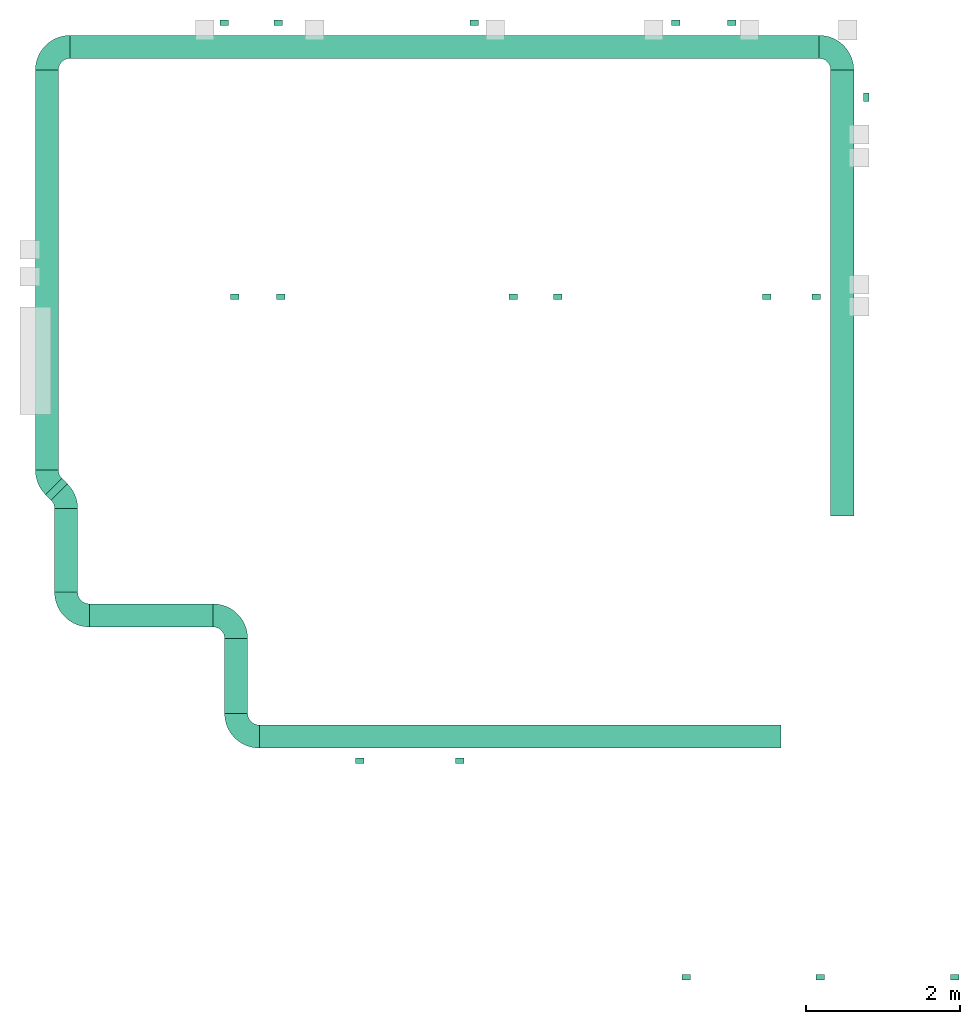
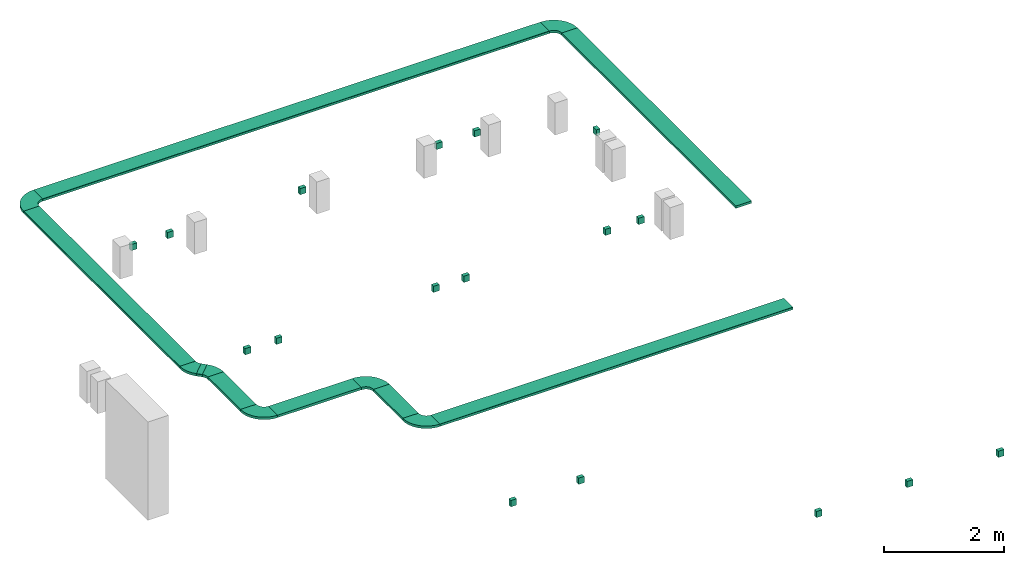
# One storey, part 1 of 2: 17 flow terminals, 15 flow fittings, 8 flow segments.
"""IFC2X3 building model written with IfcOpenShell, lengths in millimetres."""

from ifc_helpers import new_model, entity, si_unit, converted_unit, derived_unit, direction, frame, frame_2d, origin, origin_2d_with_axis, place, context, subcontext, project, spatial, polyline, circle_curve, parameter, trimmed, segment, composite_curve, rectangle, outline, extrude, source, transform, mapped, material, type_object, type_shapes, element, save


model = new_model("IFC2X3")

# Units and contexts
model_context = context("Model", 3, precision=0.01, world=origin(), true_north=direction((6.12303176911189e-17, 1.0)))
body_context = subcontext(model_context, "Body", "Model", "MODEL_VIEW")
ifc_project = project(units=[si_unit("LENGTHUNIT", "METRE", prefix="MILLI"), si_unit("AREAUNIT", "SQUARE_METRE"), si_unit("VOLUMEUNIT", "CUBIC_METRE"), converted_unit("PLANEANGLEUNIT", "DEGREE", entity("IfcRatioMeasure", 0.0174532925199433), si_unit("PLANEANGLEUNIT", "RADIAN"), dimensions=[0, 0, 0, 0, 0, 0, 0]), si_unit("MASSUNIT", "GRAM", prefix="KILO"), derived_unit("MASSDENSITYUNIT", [(si_unit("MASSUNIT", "GRAM", prefix="KILO"), 1), (si_unit("LENGTHUNIT", "METRE"), -3)]), derived_unit("MOMENTOFINERTIAUNIT", [(si_unit("LENGTHUNIT", "METRE"), 4)]), si_unit("TIMEUNIT", "SECOND"), si_unit("FREQUENCYUNIT", "HERTZ"), si_unit("THERMODYNAMICTEMPERATUREUNIT", "DEGREE_CELSIUS"), derived_unit("THERMALTRANSMITTANCEUNIT", [(si_unit("MASSUNIT", "GRAM", prefix="KILO"), 1), (si_unit("THERMODYNAMICTEMPERATUREUNIT", "KELVIN"), -1), (si_unit("TIMEUNIT", "SECOND"), -3)]), derived_unit("VOLUMETRICFLOWRATEUNIT", [(si_unit("LENGTHUNIT", "METRE"), 3), (si_unit("TIMEUNIT", "SECOND"), -1)]), derived_unit("MASSFLOWRATEUNIT", [(si_unit("MASSUNIT", "GRAM", prefix="KILO"), 1), (si_unit("TIMEUNIT", "SECOND"), -1)]), derived_unit("ROTATIONALFREQUENCYUNIT", [(si_unit("TIMEUNIT", "SECOND"), -1)]), si_unit("ELECTRICCURRENTUNIT", "AMPERE"), si_unit("ELECTRICVOLTAGEUNIT", "VOLT"), si_unit("POWERUNIT", "WATT"), si_unit("FORCEUNIT", "NEWTON", prefix="KILO"), si_unit("ILLUMINANCEUNIT", "LUX"), si_unit("LUMINOUSFLUXUNIT", "LUMEN"), si_unit("LUMINOUSINTENSITYUNIT", "CANDELA"), derived_unit("USERDEFINED", [(si_unit("MASSUNIT", "GRAM", prefix="KILO"), -1), (si_unit("LENGTHUNIT", "METRE"), -2), (si_unit("TIMEUNIT", "SECOND"), 3), (si_unit("LUMINOUSFLUXUNIT", "LUMEN"), 1)]), derived_unit("LINEARVELOCITYUNIT", [(si_unit("LENGTHUNIT", "METRE"), 1), (si_unit("TIMEUNIT", "SECOND"), -1)]), si_unit("PRESSUREUNIT", "PASCAL"), derived_unit("USERDEFINED", [(si_unit("LENGTHUNIT", "METRE"), -2), (si_unit("MASSUNIT", "GRAM", prefix="KILO"), 1), (si_unit("TIMEUNIT", "SECOND"), -2)]), derived_unit("LINEARFORCEUNIT", [(si_unit("MASSUNIT", "GRAM", prefix="KILO"), 1), (si_unit("LENGTHUNIT", "METRE"), 1), (si_unit("TIMEUNIT", "SECOND"), -2), (si_unit("LENGTHUNIT", "METRE"), -1)]), derived_unit("PLANARFORCEUNIT", [(si_unit("MASSUNIT", "GRAM", prefix="KILO"), 1), (si_unit("LENGTHUNIT", "METRE"), 1), (si_unit("TIMEUNIT", "SECOND"), -2), (si_unit("LENGTHUNIT", "METRE"), -2)])], contexts=[model_context])

# Site, building, storey
site_placement = place(None, origin())
site = spatial("IfcSite", under=ifc_project, at=site_placement, CompositionType="ELEMENT")
building_placement = place(site_placement, origin())
building = spatial("IfcBuilding", under=site, at=building_placement, CompositionType="ELEMENT")
storey_placement = place(building_placement, frame((0.0, 0.0, 199300.0)))
storey = spatial("IfcBuildingStorey", under=building, at=storey_placement, CompositionType="ELEMENT", Elevation=199300.0)

# Flow segments
cable_carrier_segment_type = type_object("IfcCableCarrierSegmentType", PredefinedType="CABLETRAYSEGMENT")
flow_segment_1_placement = place(storey_placement, frame((31710.0009155271, 13799.9992263561, 3450.0)))
element("IfcFlowSegment", 1, at=flow_segment_1_placement, inside=storey, type_object=cable_carrier_segment_type, context=body_context, shape_type="SweptSolid", body=[
    extrude(rectangle(XDim=5799.00000000001, YDim=300.000000000001, at=origin_2d_with_axis()), frame((150.0, 2899.5, 0.0), z_axis=(0.0, 0.0, 1.0), x_axis=(0.0, -1.0, 0.0)), (0.0, 0.0, 1.0), 50.0000000000233),
])
flow_segment_2_placement = place(storey_placement, frame((24281.1085349551, 10784.9986457573, 3450.0)))
element("IfcFlowSegment", 2, at=flow_segment_2_placement, inside=storey, type_object=cable_carrier_segment_type, context=body_context, shape_type="SweptSolid", body=[
    extrude(rectangle(XDim=6782.9176337415, YDim=300.000000000001, at=frame_2d((2.04636307898909e-12, 1.08002495835535e-12), x_axis=(1.0, 0.0))), frame((3391.45881687075, 150.0, 0.0), z_axis=(0.0, 0.0, 1.0), x_axis=(-1.0, 0.0, 0.0)), (0.0, 0.0, 1.0), 50.0000000000233),
])
flow_segment_3_placement = place(storey_placement, frame((23830.1085349551, 11235.9986457573, 3450.0)))
element("IfcFlowSegment", 3, at=flow_segment_3_placement, inside=storey, type_object=cable_carrier_segment_type, context=body_context, shape_type="SweptSolid", body=[
    extrude(rectangle(XDim=972.188624962087, YDim=300.000000000001, at=origin_2d_with_axis()), frame((150.0, 486.094312481047, 0.0), z_axis=(0.0, 0.0, 1.0), x_axis=(0.0, 1.0, 0.0)), (0.0, 0.0, 1.0), 50.0000000000233),
])
flow_segment_4_placement = place(storey_placement, frame((22071.1085349551, 12359.1872707193, 3450.0)))
element("IfcFlowSegment", 4, at=flow_segment_4_placement, inside=storey, type_object=cable_carrier_segment_type, context=body_context, shape_type="SweptSolid", body=[
    extrude(rectangle(XDim=1608.0, YDim=300.000000000001, at=frame_2d((2.1600499167107e-12, 0.0), x_axis=(1.0, 0.0))), frame((804.0, 150.0, 0.0), z_axis=(0.0, 0.0, 1.0), x_axis=(-1.0, 0.0, 0.0)), (0.0, 0.0, 1.0), 50.0000000000233),
])
flow_segment_5_placement = place(storey_placement, frame((21620.1085349551, 12810.1872707193, 3450.0)))
element("IfcFlowSegment", 5, at=flow_segment_5_placement, inside=storey, type_object=cable_carrier_segment_type, context=body_context, shape_type="SweptSolid", body=[
    extrude(rectangle(XDim=1087.75113021257, YDim=300.000000000001, at=frame_2d((1.08002495835535e-12, -2.17426077142591e-12), x_axis=(1.0, 0.0))), frame((150.0, 543.875565106287, 0.0), z_axis=(0.0, 0.0, 1.0), x_axis=(0.0, 1.0, 0.0)), (0.0, 0.0, 1.0), 50.0000000000233),
])
flow_segment_6_placement = place(storey_placement, frame((21370.1085349482, 14398.4665383627, 3450.0)))
element("IfcFlowSegment", 6, at=flow_segment_6_placement, inside=storey, type_object=cable_carrier_segment_type, context=body_context, shape_type="SweptSolid", body=[
    extrude(rectangle(XDim=5200.53268799345, YDim=300.000000000001, at=origin_2d_with_axis()), frame((150.0, 2600.26634399672, 0.0), z_axis=(0.0, 0.0, 1.0), x_axis=(0.0, -1.0, 0.0)), (0.0, 0.0, 1.0), 50.0000000000233),
])
flow_segment_7_placement = place(storey_placement, frame((21821.1085349482, 19749.9992263561, 3450.0)))
element("IfcFlowSegment", 7, at=flow_segment_7_placement, inside=storey, type_object=cable_carrier_segment_type, context=body_context, shape_type="SweptSolid", body=[
    extrude(rectangle(XDim=9737.89238057895, YDim=300.000000000001, at=origin_2d_with_axis()), frame((4868.94619028947, 150.0, 0.0), z_axis=(0.0, 0.0, 1.0), x_axis=(-1.0, 0.0, 0.0)), (0.0, 0.0, 1.0), 50.0000000000233),
])
flow_segment_8_placement = place(storey_placement, frame((21502.6175901954, 14005.7115248911, 3450.0)))
element("IfcFlowSegment", 8, at=flow_segment_8_placement, inside=storey, type_object=cable_carrier_segment_type, context=body_context, shape_type="SweptSolid", body=[
    extrude(rectangle(XDim=103.025253179211, YDim=299.999999999998, at=frame_2d((-1.53121959556302e-12, -1.52056145452661e-12), x_axis=(1.0, 0.0))), frame((142.49094475622, 142.49094475622, 0.0), z_axis=(0.0, 0.0, 1.0), x_axis=(-0.707106781186558, 0.707106781186537, 0.0)), (0.0, 0.0, 1.0), 50.0000000000233),
])

# Flow fittings
ifc_material = material()
cable_carrier_fitting_type_1 = type_object("IfcCableCarrierFittingType", PredefinedType="NOTDEFINED", material=ifc_material)
shared_shape_1 = source(origin(), body_context, "Body", "SweptSolid", [
    extrude(outline(composite_curve([segment(polyline([(-150.749999999996, -300.250000000003), (-149.749999999994, -300.250000000003)]), True, "CONTINUOUS"), segment(trimmed(circle_curve(frame_2d((-149.750000000002, 149.749999999997), x_axis=(0.0, -1.0)), 450.0), [parameter(0.0)], [parameter(90.0000000000001)], True, "PARAMETER"), True, "CONTINUOUS"), segment(polyline([(300.249999999997, 149.750000000005), (300.249999999997, 150.750000000004)]), True, "CONTINUOUS"), segment(polyline([(300.249999999997, 150.750000000003), (0.249999999997449, 150.750000000002)]), True, "CONTINUOUS"), segment(polyline([(0.249999999997449, 150.750000000002), (0.249999999997438, 149.75)]), True, "CONTINUOUS"), segment(trimmed(circle_curve(frame_2d((-149.750000000002, 149.749999999997), x_axis=(0.0, -1.0)), 150.0), [parameter(0.0)], [parameter(90.0000000000001)], True, "PARAMETER"), False, "CONTINUOUS"), segment(polyline([(-149.749999999999, -0.250000000002818), (-150.750000000001, -0.250000000002835)]), True, "CONTINUOUS"), segment(polyline([(-150.750000000001, -0.250000000002835), (-150.749999999996, -300.250000000003)]), True, "CONTINUOUS")], self_intersect=False)), frame((-150.249999999991, 150.249999999992, -25.0)), (0.0, 0.0, 1.0), 49.9999999999974),
])
type_shapes(cable_carrier_fitting_type_1, [shared_shape_1])
for number, where, z_axis, x_axis in (
    (9, (23980.1085349551, 12509.1872707193, 3475.0), (0.0, 0.0, 1.0), (0.0, 1.0, 0.0)),
    (10, (21770.1085349551, 12509.1872707193, 3475.0), (0.0, 0.0, 1.0), (0.0, -1.0, 0.0)),
    (11, (21520.1085349482, 19899.9992263561, 3475.0), (0.0, 0.0, 1.0), (-1.0, 0.0, 0.0)),
    (12, (31860.0009155271, 19899.9992263561, 3475.0), (0.0, 0.0, 1.0), (0.0, 1.0, 0.0)),
    (13, (23980.1085349551, 10934.9986457573, 3475.0), (0.0, 0.0, 1.0), (0.0, -1.0, 0.0)),
):
    element("IfcFlowFitting", number, at=place(storey_placement, frame(where, z_axis=z_axis, x_axis=x_axis)), inside=storey, type_object=cable_carrier_fitting_type_1, material=ifc_material, context=body_context, shape_type="MappedRepresentation", body=[
        mapped(shared_shape_1, transform((0.0, 0.0, 0.0), scale=1.0)),
    ])
cable_carrier_fitting_type_2 = type_object("IfcCableCarrierFittingType", PredefinedType="NOTDEFINED", material=ifc_material)
shared_shape_2 = source(origin(), body_context, "Body", "SweptSolid", [
    extrude(outline(composite_curve([segment(polyline([(-106.992793873276, -194.110759517316), (-105.992793873275, -194.110759517316)]), True, "CONTINUOUS"), segment(trimmed(circle_curve(frame_2d((-105.992793873283, 255.889240482683), x_axis=(0.0, -1.0)), 450.0), [parameter(0.0)], [parameter(45.0)], True, "PARAMETER"), True, "CONTINUOUS"), segment(polyline([(212.205257660669, -62.3088110512572), (212.912364441855, -61.6017042700708)]), True, "CONTINUOUS"), segment(polyline([(212.912364441855, -61.6017042700708), (0.780330085887347, 150.53033008589)]), True, "CONTINUOUS"), segment(polyline([(0.780330085887396, 150.53033008589), (0.0732233047007628, 149.823223304703)]), True, "CONTINUOUS"), segment(trimmed(circle_curve(frame_2d((-105.992793873283, 255.889240482683), x_axis=(0.0, -1.0)), 150.0), [parameter(0.0)], [parameter(45.0)], True, "PARAMETER"), False, "CONTINUOUS"), segment(polyline([(-105.99279387328, 105.889240482684), (-106.992793873281, 105.889240482684)]), True, "CONTINUOUS"), segment(polyline([(-106.992793873281, 105.889240482684), (-106.992793873276, -194.110759517316)]), True, "CONTINUOUS")], self_intersect=False)), frame((-18.27127483864, 44.1107595173065, -25.0)), (0.0, 0.0, 1.0), 49.9999999999982),
])
type_shapes(cable_carrier_fitting_type_2, [shared_shape_2])
for number, where, z_axis, x_axis in (
    (14, (21770.1085349551, 14023.2024696438, 3475.0), (0.0, 0.0, 1.0), (0.0, 1.0, 0.0)),
    (15, (21520.1085349482, 14273.2024696508, 3475.0), (0.0, 0.0, 1.0), (0.0, -1.0, 0.0)),
):
    element("IfcFlowFitting", number, at=place(storey_placement, frame(where, z_axis=z_axis, x_axis=x_axis)), inside=storey, type_object=cable_carrier_fitting_type_2, material=ifc_material, context=body_context, shape_type="MappedRepresentation", body=[
        mapped(shared_shape_2, transform((0.0, 0.0, 0.0), scale=1.0)),
    ])
cable_carrier_fitting_type_3 = type_object("IfcCableCarrierFittingType", PredefinedType="NOTDEFINED", material=ifc_material)
shared_shape_3 = source(origin(), body_context, "Body", "SweptSolid", [
    extrude(outline(polyline([(-150.0, -2.0), (-149.0, -2.0), (-149.0, 2.0), (149.0, 2.0), (149.0, -3.0), (150.0, -3.0), (150.0, 3.0), (-150.0, 3.0), (-150.0, -2.0)])), frame((0.0, 150.0, 3.0), z_axis=(1.0, 0.0, 0.0), x_axis=(0.0, 1.0, 0.0)), (0.0, 0.0, 1.0), 5200.5),
])
type_shapes(cable_carrier_fitting_type_3, [shared_shape_3])
flow_fitting_1_placement = place(storey_placement, frame((21670.1085349482, 14398.4992263561, 3494.0), z_axis=(0.0, 0.0, 1.0), x_axis=(0.0, 1.0, 0.0)))
element("IfcFlowFitting", 16, at=flow_fitting_1_placement, inside=storey, type_object=cable_carrier_fitting_type_3, material=ifc_material, context=body_context, shape_type="MappedRepresentation", body=[
    mapped(shared_shape_3, transform((0.0, 0.0, 0.0), scale=1.0)),
])
cable_carrier_fitting_type_4 = type_object("IfcCableCarrierFittingType", PredefinedType="NOTDEFINED", material=ifc_material)
shared_shape_4 = source(origin(), body_context, "Body", "SweptSolid", [
    extrude(outline(polyline([(-150.0, -2.0), (-149.0, -2.0), (-149.0, 2.0), (149.0, 2.0), (149.0, -3.0), (150.0, -3.0), (150.0, 3.0), (-150.0, 3.0), (-150.0, -2.0)])), frame((0.0, 150.0, 3.0), z_axis=(1.0, 0.0, 0.0), x_axis=(0.0, 1.0, 0.0)), (0.0, 0.0, 1.0), 9737.9),
])
type_shapes(cable_carrier_fitting_type_4, [shared_shape_4])
flow_fitting_2_placement = place(storey_placement, frame((31559.0085349482, 20049.9992263561, 3494.0), z_axis=(0.0, 0.0, 1.0), x_axis=(-1.0, 0.0, 0.0)))
element("IfcFlowFitting", 17, at=flow_fitting_2_placement, inside=storey, type_object=cable_carrier_fitting_type_4, material=ifc_material, context=body_context, shape_type="MappedRepresentation", body=[
    mapped(shared_shape_4, transform((0.0, 0.0, 0.0), scale=1.0)),
])
cable_carrier_fitting_type_5 = type_object("IfcCableCarrierFittingType", PredefinedType="NOTDEFINED", material=ifc_material)
shared_shape_5 = source(origin(), body_context, "Body", "SweptSolid", [
    extrude(outline(polyline([(-150.0, -2.0), (-149.0, -2.0), (-149.0, 2.0), (149.0, 2.0), (149.0, -3.0), (150.0, -3.0), (150.0, 3.0), (-150.0, 3.0), (-150.0, -2.0)])), frame((0.0, 150.0, 3.0), z_axis=(1.0, 0.0, 0.0), x_axis=(0.0, 1.0, 0.0)), (0.0, 0.0, 1.0), 103.0),
])
type_shapes(cable_carrier_fitting_type_5, [shared_shape_5])
flow_fitting_3_placement = place(storey_placement, frame((21787.5816230136, 14217.8614159413, 3494.0), z_axis=(0.0, 0.0, 1.0), x_axis=(-0.707106781186548, 0.707106781186548, 0.0)))
element("IfcFlowFitting", 18, at=flow_fitting_3_placement, inside=storey, type_object=cable_carrier_fitting_type_5, material=ifc_material, context=body_context, shape_type="MappedRepresentation", body=[
    mapped(shared_shape_5, transform((0.0, 0.0, 0.0), scale=1.0)),
])
cable_carrier_fitting_type_6 = type_object("IfcCableCarrierFittingType", PredefinedType="NOTDEFINED", material=ifc_material)
shared_shape_6 = source(origin(), body_context, "Body", "SweptSolid", [
    extrude(outline(polyline([(-150.0, -2.0), (-149.0, -2.0), (-149.0, 2.0), (149.0, 2.0), (149.0, -3.0), (150.0, -3.0), (150.0, 3.0), (-150.0, 3.0), (-150.0, -2.0)])), frame((0.0, 150.0, 3.0), z_axis=(1.0, 0.0, 0.0), x_axis=(0.0, 1.0, 0.0)), (0.0, 0.0, 1.0), 1087.8),
])
type_shapes(cable_carrier_fitting_type_6, [shared_shape_6])
flow_fitting_4_placement = place(storey_placement, frame((21920.1085349551, 12810.1384009319, 3494.0), z_axis=(0.0, 0.0, 1.0), x_axis=(0.0, 1.0, 0.0)))
element("IfcFlowFitting", 19, at=flow_fitting_4_placement, inside=storey, type_object=cable_carrier_fitting_type_6, material=ifc_material, context=body_context, shape_type="MappedRepresentation", body=[
    mapped(shared_shape_6, transform((0.0, 0.0, 0.0), scale=1.0)),
])
cable_carrier_fitting_type_7 = type_object("IfcCableCarrierFittingType", PredefinedType="NOTDEFINED", material=ifc_material)
shared_shape_7 = source(origin(), body_context, "Body", "SweptSolid", [
    extrude(outline(polyline([(-150.0, -2.0), (-149.0, -2.0), (-149.0, 2.0), (149.0, 2.0), (149.0, -3.0), (150.0, -3.0), (150.0, 3.0), (-150.0, 3.0), (-150.0, -2.0)])), frame((0.0, 150.0, 3.0), z_axis=(1.0, 0.0, 0.0), x_axis=(0.0, 1.0, 0.0)), (0.0, 0.0, 1.0), 5798.96406871193),
])
type_shapes(cable_carrier_fitting_type_7, [shared_shape_7])
flow_fitting_5_placement = place(storey_placement, frame((32010.0009155272, 13799.9992263561, 3494.0), z_axis=(0.0, 0.0, 1.0), x_axis=(0.0, 1.0, 0.0)))
element("IfcFlowFitting", 20, at=flow_fitting_5_placement, inside=storey, type_object=cable_carrier_fitting_type_7, material=ifc_material, context=body_context, shape_type="MappedRepresentation", body=[
    mapped(shared_shape_7, transform((0.0, 0.0, 0.0), scale=1.0)),
])
cable_carrier_fitting_type_8 = type_object("IfcCableCarrierFittingType", PredefinedType="NOTDEFINED", material=ifc_material)
shared_shape_8 = source(origin(), body_context, "Body", "SweptSolid", [
    extrude(outline(polyline([(-150.0, -2.0), (-149.0, -2.0), (-149.0, 2.0), (149.0, 2.0), (149.0, -3.0), (150.0, -3.0), (150.0, 3.0), (-150.0, 3.0), (-150.0, -2.0)])), frame((0.0, 150.0, 3.0), z_axis=(1.0, 0.0, 0.0), x_axis=(0.0, 1.0, 0.0)), (0.0, 0.0, 1.0), 1608.0),
])
type_shapes(cable_carrier_fitting_type_8, [shared_shape_8])
flow_fitting_6_placement = place(storey_placement, frame((22071.1085349551, 12359.1872707194, 3494.0)))
element("IfcFlowFitting", 21, at=flow_fitting_6_placement, inside=storey, type_object=cable_carrier_fitting_type_8, material=ifc_material, context=body_context, shape_type="MappedRepresentation", body=[
    mapped(shared_shape_8, transform((0.0, 0.0, 0.0), scale=1.0)),
])
cable_carrier_fitting_type_9 = type_object("IfcCableCarrierFittingType", PredefinedType="NOTDEFINED", material=ifc_material)
shared_shape_9 = source(origin(), body_context, "Body", "SweptSolid", [
    extrude(outline(polyline([(-150.0, -2.0), (-149.0, -2.0), (-149.0, 2.0), (149.0, 2.0), (149.0, -3.0), (150.0, -3.0), (150.0, 3.0), (-150.0, 3.0), (-150.0, -2.0)])), frame((0.0, 150.0, 3.0), z_axis=(1.0, 0.0, 0.0), x_axis=(0.0, 1.0, 0.0)), (0.0, 0.0, 1.0), 972.2),
])
type_shapes(cable_carrier_fitting_type_9, [shared_shape_9])
flow_fitting_7_placement = place(storey_placement, frame((24130.1085349551, 11235.9986457573, 3494.0), z_axis=(0.0, 0.0, 1.0), x_axis=(0.0, 1.0, 0.0)))
element("IfcFlowFitting", 22, at=flow_fitting_7_placement, inside=storey, type_object=cable_carrier_fitting_type_9, material=ifc_material, context=body_context, shape_type="MappedRepresentation", body=[
    mapped(shared_shape_9, transform((0.0, 0.0, 0.0), scale=1.0)),
])
cable_carrier_fitting_type_10 = type_object("IfcCableCarrierFittingType", PredefinedType="NOTDEFINED", material=ifc_material)
shared_shape_10 = source(origin(), body_context, "Body", "SweptSolid", [
    extrude(outline(polyline([(-150.0, -2.0), (-149.0, -2.0), (-149.0, 2.0), (149.0, 2.0), (149.0, -3.0), (150.0, -3.0), (150.0, 3.0), (-150.0, 3.0), (-150.0, -2.0)])), frame((0.0, 150.0, 3.0), z_axis=(1.0, 0.0, 0.0), x_axis=(0.0, 1.0, 0.0)), (0.0, 0.0, 1.0), 6782.1),
])
type_shapes(cable_carrier_fitting_type_10, [shared_shape_10])
flow_fitting_8_placement = place(storey_placement, frame((24281.1085349551, 10784.9986457573, 3494.0)))
element("IfcFlowFitting", 23, at=flow_fitting_8_placement, inside=storey, type_object=cable_carrier_fitting_type_10, material=ifc_material, context=body_context, shape_type="MappedRepresentation", body=[
    mapped(shared_shape_10, transform((0.0, 0.0, 0.0), scale=1.0)),
])

# Flow terminals
electric_appliance_type = type_object("IfcElectricApplianceType", Name="ADSK_:RT 262 A", PredefinedType="NOTDEFINED", material=ifc_material)
shared_shape_11 = source(origin(), body_context, "Body", "SweptSolid", [
    extrude(rectangle(XDim=71.0, YDim=110.000000000044, at=origin_2d_with_axis()), frame((0.0, 0.0, 0.0), z_axis=(0.0, 0.0, 1.0), x_axis=(-1.0, 0.0, 0.0)), (0.0, 0.0, 1.0), 127.0),
])
type_shapes(electric_appliance_type, [shared_shape_11])
for number, where, z_axis, x_axis, name in (
    (24, (23825.1085349482, 20214.499226356, 1500.0), (0.0, 0.0, 1.0), (0.0, -1.0, 0.0), "ADSK_:RT 262 A"),
    (25, (24525.1085349482, 20214.499226356, 1500.0), (0.0, 0.0, 1.0), (0.0, -1.0, 0.0), "ADSK_:RT 262 A"),
    (26, (27075.1085349482, 20214.499226356, 1500.0), (0.0, 0.0, 1.0), (0.0, -1.0, 0.0), "ADSK_:RT 262 A"),
    (27, (29695.1085349482, 20214.499226356, 1500.0), (0.0, 0.0, 1.0), (0.0, -1.0, 0.0), "ADSK_:RT 262 A"),
    (28, (30425.1085349482, 20214.499226356, 1500.0), (0.0, 0.0, 1.0), (0.0, -1.0, 0.0), "ADSK_:RT 262 A"),
    (29, (32174.5009155272, 19244.9992263562, 1500.0), (0.0, 0.0, 1.0), (-1.0, 0.0, 0.0), "ADSK_:RT 262 A"),
    (30, (31520.0009155271, 16649.999226356, 1500.0), (0.0, 0.0, 1.0), (0.0, 1.0, 0.0), "ADSK_:RT 262 A"),
    (31, (30880.0009155271, 16649.999226356, 1500.0), (0.0, 0.0, 1.0), (0.0, 1.0, 0.0), "ADSK_:RT 262 A"),
    (32, (28160.0009155271, 16649.999226356, 1500.0), (0.0, 0.0, 1.0), (0.0, 1.0, 0.0), "ADSK_:RT 262 A"),
    (33, (27580.0009155271, 16649.999226356, 1500.0), (0.0, 0.0, 1.0), (0.0, 1.0, 0.0), "ADSK_:RT 262 A"),
    (34, (24560.0009155271, 16649.999226356, 1500.0), (0.0, 0.0, 1.0), (0.0, 1.0, 0.0), "ADSK_:RT 262 A"),
    (35, (23960.0009155271, 16649.999226356, 1500.0), (0.0, 0.0, 1.0), (0.0, 1.0, 0.0), "ADSK_:RT 262 A"),
    (36, (25585.1085349551, 10620.4986457573, 1500.0), (0.0, 0.0, 1.0), (0.0, 1.0, 0.0), "ADSK_:RT 262 A"),
    (37, (26885.1085349551, 10620.4986457573, 1500.0), (0.0, 0.0, 1.0), (0.0, 1.0, 0.0), "ADSK_:RT 262 A"),
    (38, (29830.0002685552, 7804.4987060312, 1500.0), (0.0, 0.0, 1.0), (0.0, -1.0, 0.0), "ADSK_:RT 262 A"),
    (39, (31575.0002685552, 7804.4987060312, 1500.0), (0.0, 0.0, 1.0), (0.0, -1.0, 0.0), "ADSK_:RT 262 A"),
    (40, (33325.0002685552, 7804.49870603119, 1500.0), (0.0, 0.0, 1.0), (0.0, -1.0, 0.0), "ADSK_:RT 262 A"),
):
    element("IfcFlowTerminal", number, at=place(storey_placement, frame(where, z_axis=z_axis, x_axis=x_axis)), inside=storey, type_object=electric_appliance_type, material=ifc_material, Name=name, ObjectType="ADSK_:RT 262 A", context=body_context, shape_type="MappedRepresentation", body=[
        mapped(shared_shape_11, transform((0.0, 0.0, 0.0), scale=1.0)),
    ])

save(model, "model.ifc")
